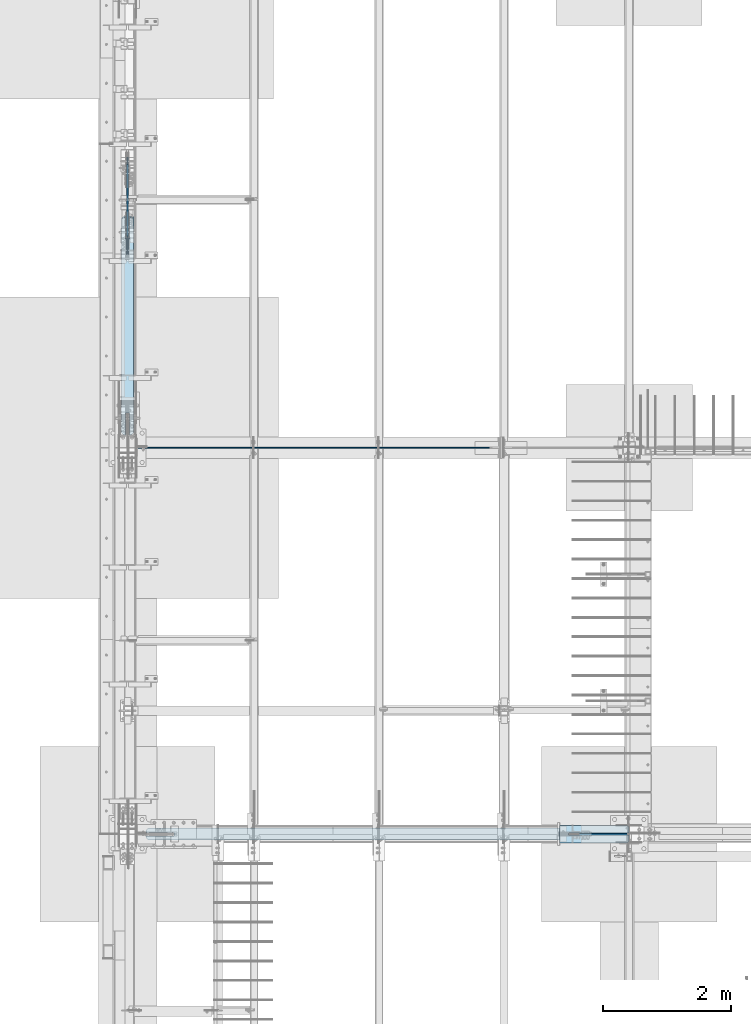
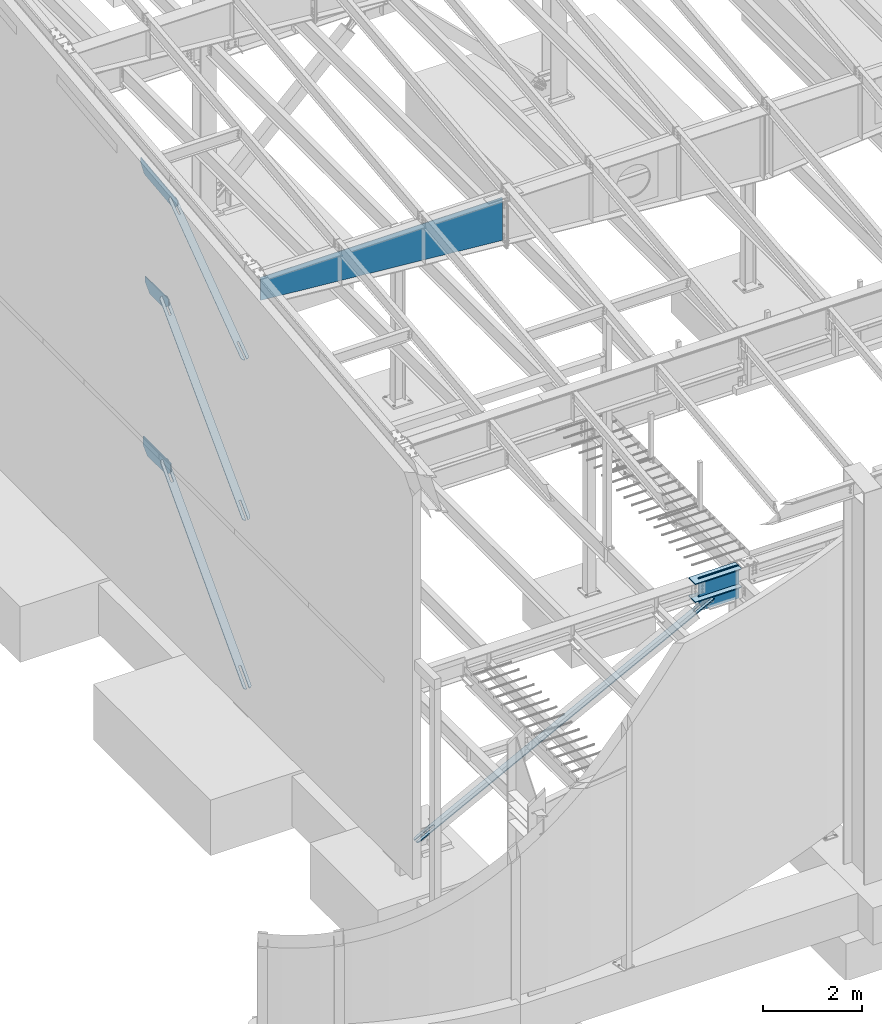
# One storey, part 967 of 1179: 11 plates, 9 elements without a shape of their own.
"""IFC2X3 building model written with IfcOpenShell, lengths in millimetres."""

from ifc_helpers import new_model, si_unit, frame, origin_with_axes, place, context, subcontext, project, spatial, faceted_brep, material, type_object, element, aggregate, save


model = new_model("IFC2X3")

# Units and contexts
model_context = context("Model", 3, precision=1e-05, world=origin_with_axes())
body_context = subcontext(model_context, "Body", "Model", "MODEL_VIEW")
ifc_project = project(units=[si_unit("LENGTHUNIT", "METRE", prefix="MILLI"), si_unit("AREAUNIT", "SQUARE_METRE"), si_unit("VOLUMEUNIT", "CUBIC_METRE"), si_unit("MASSUNIT", "GRAM", prefix="KILO"), si_unit("TIMEUNIT", "SECOND"), si_unit("PLANEANGLEUNIT", "RADIAN"), si_unit("SOLIDANGLEUNIT", "STERADIAN"), si_unit("THERMODYNAMICTEMPERATUREUNIT", "DEGREE_CELSIUS"), si_unit("LUMINOUSINTENSITYUNIT", "LUMEN")], contexts=[model_context])

# Site, building, storey
site_placement = place(None, origin_with_axes())
site = spatial("IfcSite", under=ifc_project, at=site_placement, CompositionType="ELEMENT")
building_placement = place(site_placement, origin_with_axes())
building = spatial("IfcBuilding", under=site, at=building_placement, Name="Undefined", CompositionType="ELEMENT")
storey_placement = place(building_placement, origin_with_axes())
storey = spatial("IfcBuildingStorey", under=building, at=storey_placement, Name="Undefined", CompositionType="ELEMENT", Elevation=0.0)

# Assembly, plate
assembly_1_placement = place(storey_placement, origin_with_axes())
assembly_1 = element("IfcElementAssembly", 1, at=assembly_1_placement, inside=storey, Name="BEAM", AssemblyPlace="NOTDEFINED", PredefinedType="RIGID_FRAME")
ifc_material_1 = material(Name="STEEL/A572-GR.50")
plate_type_1 = type_object("IfcPlateType", PredefinedType="NOTDEFINED")
plate_1_placement = place(assembly_1_placement, frame((431.800000000002, 14878.05, 7539.60905052727), z_axis=(0.0, 1.0, 0.0), x_axis=(0.0, 0.0, 1.0)))
plate_1 = element("IfcPlate", 2, at=plate_1_placement, type_object=plate_type_1, material=ifc_material_1, Name="PLATE", context=body_context, shape_type="Brep", body=[
    faceted_brep([(0.0, -9.52499999999964, 0.0), (-186.309050642565, -9.52500000000146, 190.890420911079), (-186.309050642565, 9.52500000000146, 190.890420911079), (0.0, 9.52499999999964, 0.0), (-186.30905049287, -9.52500000000146, 482.600000483581), (-186.30905049287, 9.52500000000146, 482.600000483581), (-186.309050331894, -9.52500000000146, 761.609579128339), (-186.309050331894, 9.52500000000146, 761.609579128339), (6.76212039252277e-07, -9.52500000000146, 952.499999997119), (6.76212039252277e-07, 9.52500000000146, 952.499999997119), (143.89094955044, -9.52500000000146, 952.500000233997), (143.89094955044, 9.52500000000146, 952.500000233997), (143.890949095251, -9.52500000000146, 0.0), (143.890949095251, 9.52500000000146, 0.0)], [[[0, 1, 2, 3]], [[1, 4, 5, 2]], [[4, 6, 7, 5]], [[6, 8, 9, 7]], [[8, 10, 11, 9]], [[10, 12, 13, 11]], [[12, 0, 3, 13]], [[5, 7, 9, 11, 13, 3, 2]], [[12, 10, 8, 6, 4, 1, 0]]]),
])
aggregate(assembly_1, [plate_1])

# Assembly, plates
assembly_2_placement = place(storey_placement, origin_with_axes())
assembly_2 = element("IfcElementAssembly", 3, at=assembly_2_placement, inside=storey, Name="COLUMN", AssemblyPlace="NOTDEFINED", PredefinedType="RIGID_FRAME")
plate_type_2 = type_object("IfcPlateType", PredefinedType="NOTDEFINED")
plate_2_placement = place(assembly_2_placement, frame((7187.72922453646, 5572.12499999999, 3646.4875), z_axis=(0.0, -1.0, 0.0), x_axis=(1.0, 0.0, 0.0)))
plate_2 = element("IfcPlate", 4, at=plate_2_placement, type_object=plate_type_2, material=ifc_material_1, Name="PLATE", context=body_context, shape_type="Brep", body=[
    faceted_brep([(0.0, -11.1125000000002, 0.0), (0.0, -11.1125000000002, 273.050000000003), (0.0, 11.1125000000002, 273.050000000003), (0.0, 11.1125000000002, 0.0), (1064.88952510486, -11.1125000000002, 273.050006103513), (1064.88952510486, 11.1125000000002, 273.050006103513), (1087.11452548633, -11.1125000000002, 250.825005722043), (1087.11452548633, 11.1125000000002, 250.825005722043), (1087.11452548633, -11.1125000000002, 150.812499999992), (1087.11452548633, 11.1125000000002, 150.812499999992), (154.761317976112, -11.1125000000002, 150.812499999992), (154.761317976112, 11.1125000000002, 150.812499999992), (149.293728290214, -11.1125000000002, 149.724928791709), (149.293728290214, 11.1125000000002, 149.724928791709), (144.65852957017, -11.1125000000002, 146.627788024464), (144.65852957017, 11.1125000000002, 146.627788024464), (141.561388802925, -11.1125000000002, 141.99258930442), (141.561388802925, 11.1125000000002, 141.99258930442), (140.473817594642, -11.1125000000002, 136.525000381463), (140.473817594642, 11.1125000000002, 136.525000381463), (141.561388802925, -11.1125000000002, 131.057410695565), (141.561388802925, 11.1125000000002, 131.057410695565), (144.65852957017, -11.1125000000002, 126.42221197552), (144.65852957017, 11.1125000000002, 126.42221197552), (149.293728290214, -11.1125000000002, 123.325071208275), (149.293728290214, 11.1125000000002, 123.325071208275), (154.761317976112, -11.1125000000002, 122.237499999993), (154.761317976112, 11.1125000000002, 122.237499999993), (1087.11452548633, -11.1125000000002, 122.237499999993), (1087.11452548633, 11.1125000000002, 122.237499999993), (1087.11452548633, -11.1125000000002, 22.2250003814697), (1087.11452548633, 11.1125000000002, 22.2250003814697), (1064.88952510486, -11.1125000000002, 0.0), (1064.88952510486, 11.1125000000002, 0.0)], [[[0, 1, 2, 3]], [[1, 4, 5, 2]], [[4, 6, 7, 5]], [[6, 8, 9, 7]], [[8, 10, 11, 9]], [[10, 12, 13, 11]], [[12, 14, 15, 13]], [[14, 16, 17, 15]], [[16, 18, 19, 17]], [[18, 20, 21, 19]], [[20, 22, 23, 21]], [[22, 24, 25, 23]], [[24, 26, 27, 25]], [[26, 28, 29, 27]], [[28, 30, 31, 29]], [[30, 32, 33, 31]], [[32, 0, 3, 33]], [[5, 7, 9, 11, 13, 15, 17, 19, 21, 23, 25, 27, 29, 31, 33, 3, 2]], [[32, 30, 28, 26, 24, 22, 20, 18, 16, 14, 12, 10, 8, 6, 4, 1, 0]]]),
])
plate_3_placement = place(assembly_2_placement, frame((7187.72922453646, 5572.12499999999, 4090.9875), z_axis=(0.0, -1.0, 0.0), x_axis=(1.0, 0.0, 0.0)))
plate_3 = element("IfcPlate", 5, at=plate_3_placement, type_object=plate_type_2, material=ifc_material_1, Name="PLATE", context=body_context, shape_type="Brep", body=[
    faceted_brep([(0.0, -11.1125000000002, 0.0), (0.0, -11.1125000000002, 273.050000000003), (0.0, 11.1125000000002, 273.050000000003), (0.0, 11.1125000000002, 0.0), (1064.88952510486, -11.1125000000002, 273.050006103513), (1064.88952510486, 11.1125000000002, 273.050006103513), (1087.11452548633, -11.1125000000002, 250.825005722043), (1087.11452548633, 11.1125000000002, 250.825005722043), (1087.11452548633, -11.1125000000002, 150.812499999992), (1087.11452548633, 11.1125000000002, 150.812499999992), (154.761317976112, -11.1125000000002, 150.812499999992), (154.761317976112, 11.1125000000002, 150.812499999992), (149.293728290214, -11.1125000000002, 149.724928791709), (149.293728290214, 11.1125000000002, 149.724928791709), (144.65852957017, -11.1125000000002, 146.627788024464), (144.65852957017, 11.1125000000002, 146.627788024464), (141.561388802925, -11.1125000000002, 141.99258930442), (141.561388802925, 11.1125000000002, 141.99258930442), (140.473817594642, -11.1125000000002, 136.525000381463), (140.473817594642, 11.1125000000002, 136.525000381463), (141.561388802925, -11.1125000000002, 131.057410695565), (141.561388802925, 11.1125000000002, 131.057410695565), (144.65852957017, -11.1125000000002, 126.42221197552), (144.65852957017, 11.1125000000002, 126.42221197552), (149.293728290214, -11.1125000000002, 123.325071208275), (149.293728290214, 11.1125000000002, 123.325071208275), (154.761317976112, -11.1125000000002, 122.237499999993), (154.761317976112, 11.1125000000002, 122.237499999993), (1087.11452548633, -11.1125000000002, 122.237499999993), (1087.11452548633, 11.1125000000002, 122.237499999993), (1087.11452548633, -11.1125000000002, 22.2250003814697), (1087.11452548633, 11.1125000000002, 22.2250003814697), (1064.88952510486, -11.1125000000002, 0.0), (1064.88952510486, 11.1125000000002, 0.0)], [[[0, 1, 2, 3]], [[1, 4, 5, 2]], [[4, 6, 7, 5]], [[6, 8, 9, 7]], [[8, 10, 11, 9]], [[10, 12, 13, 11]], [[12, 14, 15, 13]], [[14, 16, 17, 15]], [[16, 18, 19, 17]], [[18, 20, 21, 19]], [[20, 22, 23, 21]], [[22, 24, 25, 23]], [[24, 26, 27, 25]], [[26, 28, 29, 27]], [[28, 30, 31, 29]], [[30, 32, 33, 31]], [[32, 0, 3, 33]], [[5, 7, 9, 11, 13, 15, 17, 19, 21, 23, 25, 27, 29, 31, 33, 3, 2]], [[32, 30, 28, 26, 24, 22, 20, 18, 16, 14, 12, 10, 8, 6, 4, 1, 0]]]),
])

# Assembly, plate
assembly_3_placement = place(storey_placement, origin_with_axes())
assembly_3 = element("IfcElementAssembly", 6, at=assembly_3_placement, inside=storey, Name="CB", AssemblyPlace="NOTDEFINED", PredefinedType="RIGID_FRAME")
ifc_material_2 = material(Name="STEEL/A36")
plate_type_3 = type_object("IfcPlateType", PredefinedType="NOTDEFINED")
plate_4_placement = place(assembly_3_placement, frame((522.287500000002, 11774.6047955765, 8077.03322111538), z_axis=(0.0, 0.806043266248581, 0.591856615182528), x_axis=(-1.0, 0.0, 0.0)))
plate_4 = element("IfcPlate", 7, at=plate_4_placement, type_object=plate_type_3, material=ifc_material_2, Name="CB", context=body_context, shape_type="Brep", body=[
    faceted_brep([(0.0, -6.34999999991851, 71.4374999999018), (0.0, -6.34999999920291, 3657.25747777707), (0.0, 6.3500000008051, 3657.25747777707), (0.0, 6.35000000007858, 71.4374999999018), (5.43785589622496, -6.34999999919745, 3684.59542547663), (5.43785589622496, 6.35000000080873, 3684.59542547663), (20.923559318986, -6.34999999919199, 3707.77141845805), (20.923559318986, 6.35000000081419, 3707.77141845804), (44.0995523004189, -6.34999999919017, 3723.2571218808), (44.0995523004189, 6.35000000081783, 3723.25712188079), (71.4375, -6.34999999918654, 3728.69497777702), (71.4375, 6.35000000081965, 3728.69497777701), (71.4375, -6.34999999927476, 3321.6724888803), (71.4375, 6.3500000007287, 3321.67248888029), (109.537499999999, -6.34999999927476, 3321.6724888803), (109.537499999999, 6.3500000007287, 3321.67248888029), (109.537499999999, -6.34999999918654, 3728.69497777702), (109.537499999999, 6.35000000081965, 3728.69497777701), (136.87544769958, -6.34999999919017, 3723.2571218808), (136.87544769958, 6.35000000081783, 3723.25712188079), (160.051440681013, -6.34999999919199, 3707.77141845805), (160.051440681013, 6.35000000081419, 3707.77141845804), (175.537144103774, -6.34999999919745, 3684.59542547663), (175.537144103774, 6.35000000080873, 3684.59542547663), (180.974999999999, -6.34999999920291, 3657.25747777707), (180.974999999999, 6.3500000008051, 3657.25747777707), (180.975000000006, -6.34999999991851, 71.4374999999018), (180.975000000006, 6.35000000007858, 71.4374999999018), (175.537144103779, -6.34999999995125, 44.0995523003585), (175.537144103779, 6.35000000004584, 44.0995523003585), (160.051440681018, -6.34999999997672, 20.9235593189551), (160.051440681018, 6.35000000002401, 20.9235593189587), (136.875447699589, -6.34999999999491, 5.43785589621984), (136.875447699589, 6.35000000000218, 5.43785589621621), (109.537500000006, -6.34999999999854, 3.63797880709171e-12), (109.537500000006, 6.35000000000218, 0.0), (109.537499999999, -6.34999999991595, 407.022488896726), (109.537499999999, 6.35000000009114, 407.022488896719), (71.4375, -6.34999999991595, 407.022488896726), (71.4375, 6.35000000009114, 407.022488896719), (71.4375, -6.34999999999854, 3.63797880709171e-12), (71.4375, 6.35000000000218, 0.0), (44.0995523004167, -6.34999999999491, 5.43785589621984), (44.0995523004167, 6.35000000000218, 5.43785589621621), (20.9235593189878, -6.34999999997672, 20.9235593189551), (20.9235593189878, 6.35000000002401, 20.9235593189587), (5.43785589622712, -6.34999999995125, 44.0995523003585), (5.43785589622712, 6.35000000004584, 44.0995523003585)], [[[0, 1, 2, 3]], [[1, 4, 5, 2]], [[4, 6, 7, 5]], [[6, 8, 9, 7]], [[8, 10, 11, 9]], [[10, 12, 13, 11]], [[12, 14, 15, 13]], [[14, 16, 17, 15]], [[16, 18, 19, 17]], [[18, 20, 21, 19]], [[20, 22, 23, 21]], [[22, 24, 25, 23]], [[24, 26, 27, 25]], [[26, 28, 29, 27]], [[28, 30, 31, 29]], [[30, 32, 33, 31]], [[32, 34, 35, 33]], [[34, 36, 37, 35]], [[36, 38, 39, 37]], [[38, 40, 41, 39]], [[40, 42, 43, 41]], [[42, 44, 45, 43]], [[44, 46, 47, 45]], [[46, 0, 3, 47]], [[5, 7, 9, 11, 13, 15, 17, 19, 21, 23, 25, 27, 29, 31, 33, 35, 37, 39, 41, 43, 45, 47, 3, 2]], [[46, 44, 42, 40, 38, 36, 34, 32, 30, 28, 26, 24, 22, 20, 18, 16, 14, 12, 10, 8, 6, 4, 1, 0]]]),
])
aggregate(assembly_3, [plate_4])

assembly_4_placement = place(storey_placement, origin_with_axes())
assembly_4 = element("IfcElementAssembly", 8, at=assembly_4_placement, inside=storey, Name="CB", AssemblyPlace="NOTDEFINED", PredefinedType="RIGID_FRAME")
plate_type_4 = type_object("IfcPlateType", PredefinedType="NOTDEFINED")
plate_5_placement = place(assembly_4_placement, frame((525.462500000002, 11730.1540469199, 4148.03570453558), z_axis=(0.0, 0.698466923036852, 0.715642339037758), x_axis=(-1.0, 0.0, 0.0)))
plate_5 = element("IfcPlate", 9, at=plate_5_placement, type_object=plate_type_4, material=ifc_material_2, Name="CB", context=body_context, shape_type="Brep", body=[
    faceted_brep([(0.0, -9.52500000000691, 71.4375), (0.0, -9.52499999965221, 4791.84892355422), (0.0, 9.52500000033979, 4791.84892355423), (0.0, 9.52500000000327, 71.4374999999909), (5.43785589622496, -9.52499999964857, 4819.1868712538), (5.43785589622496, 9.52500000034343, 4819.18687125381), (20.923559318986, -9.52499999964857, 4842.36286423524), (20.923559318986, 9.52500000034343, 4842.36286423525), (44.0995523004189, -9.52499999964493, 4857.848567658), (44.0995523004189, 9.52500000034343, 4857.84856765801), (71.4375, -9.52499999964493, 4863.28642355423), (71.4375, 9.52500000034706, 4863.28642355424), (71.4375, -9.52499999967404, 4441.70468275449), (71.4375, 9.52500000031432, 4441.7046827545), (115.8875, -9.52499999967404, 4441.70468275449), (115.8875, 9.52500000031432, 4441.7046827545), (115.8875, -9.52499999964493, 4863.28642355423), (115.8875, 9.52500000034706, 4863.28642355424), (143.225447699581, -9.52499999964493, 4857.848567658), (143.225447699581, 9.52500000034343, 4857.84856765801), (166.401440681014, -9.52499999964857, 4842.36286423524), (166.401440681014, 9.52500000034343, 4842.36286423525), (181.887144103775, -9.52499999964857, 4819.1868712538), (181.887144103775, 9.52500000034343, 4819.18687125381), (187.325, -9.52499999965221, 4791.84892355422), (187.325, 9.52500000033979, 4791.84892355423), (187.324999999997, -9.52500000000691, 71.4375), (187.324999999997, 9.52500000000327, 71.4374999999909), (181.88714410377, -9.52500000000691, 44.0995523004203), (181.88714410377, 9.52500000000509, 44.0995523004112), (166.401440681009, -9.52500000000691, 20.9235593189915), (166.401440681009, 9.52500000000509, 20.9235593189787), (143.22544769958, -9.52500000000327, 5.43785589623076), (143.22544769958, 9.52500000000509, 5.43785589621621), (115.887499999997, -9.52500000000509, 5.45696821063757e-12), (115.887499999997, 9.52500000000691, -7.27595761418343e-12), (115.887499999997, -9.52500000001783, 421.581740798863), (115.887499999997, 9.52499999999418, 421.581740798851), (71.4375, -9.52500000001783, 421.581740798863), (71.4375, 9.52499999999418, 421.581740798851), (71.4375, -9.52500000000509, 5.45696821063757e-12), (71.4375, 9.52500000000691, -7.27595761418343e-12), (44.0995523004167, -9.52500000000327, 5.43785589623076), (44.0995523004167, 9.52500000000509, 5.43785589621621), (20.9235593189878, -9.52500000000691, 20.9235593189915), (20.9235593189878, 9.52500000000509, 20.9235593189787), (5.43785589622712, -9.52500000000691, 44.0995523004203), (5.43785589622712, 9.52500000000509, 44.0995523004112)], [[[0, 1, 2, 3]], [[1, 4, 5, 2]], [[4, 6, 7, 5]], [[6, 8, 9, 7]], [[8, 10, 11, 9]], [[10, 12, 13, 11]], [[12, 14, 15, 13]], [[14, 16, 17, 15]], [[16, 18, 19, 17]], [[18, 20, 21, 19]], [[20, 22, 23, 21]], [[22, 24, 25, 23]], [[24, 26, 27, 25]], [[26, 28, 29, 27]], [[28, 30, 31, 29]], [[30, 32, 33, 31]], [[32, 34, 35, 33]], [[34, 36, 37, 35]], [[36, 38, 39, 37]], [[38, 40, 41, 39]], [[40, 42, 43, 41]], [[42, 44, 45, 43]], [[44, 46, 47, 45]], [[46, 0, 3, 47]], [[5, 7, 9, 11, 13, 15, 17, 19, 21, 23, 25, 27, 29, 31, 33, 35, 37, 39, 41, 43, 45, 47, 3, 2]], [[46, 44, 42, 40, 38, 36, 34, 32, 30, 28, 26, 24, 22, 20, 18, 16, 14, 12, 10, 8, 6, 4, 1, 0]]]),
])
aggregate(assembly_4, [plate_5])

assembly_5_placement = place(storey_placement, origin_with_axes())
assembly_5 = element("IfcElementAssembly", 10, at=assembly_5_placement, inside=storey, Name="BEAM", AssemblyPlace="NOTDEFINED", PredefinedType="RIGID_FRAME")
plate_type_5 = type_object("IfcPlateType", PredefinedType="NOTDEFINED")
plate_6_placement = place(assembly_5_placement, frame((431.800000000002, 14793.6602577624, 3473.77993843472), z_axis=(0.0, 1.0, 0.0), x_axis=(0.0, 0.0, 1.0)))
plate_6 = element("IfcPlate", 11, at=plate_6_placement, type_object=plate_type_5, material=ifc_material_1, Name="PLATE", context=body_context, shape_type="Brep", body=[
    faceted_brep([(0.0, -12.7, 0.0), (-165.530801027491, -12.7, 175.571193903201), (-165.530801027491, 12.7, 175.571193903201), (0.0, 12.7, 0.0), (-165.530801027491, -12.7, 566.989741928064), (-165.530801027491, 12.7, 566.989741928064), (-165.530801027491, -12.7, 945.708290572049), (-165.530801027491, 12.7, 945.708290572049), (-3.09023562294897e-07, -12.7, 1121.27948414748), (-3.09023562294897e-07, 12.7, 1121.27948414748), (209.22006156528, -12.7, 1121.27948414748), (209.22006156528, 12.7, 1121.27948414748), (209.22006156528, -12.7, -3.63797880709171e-12), (209.22006156528, 12.7, -3.63797880709171e-12)], [[[0, 1, 2, 3]], [[1, 4, 5, 2]], [[4, 6, 7, 5]], [[6, 8, 9, 7]], [[8, 10, 11, 9]], [[10, 12, 13, 11]], [[12, 0, 3, 13]], [[5, 7, 9, 11, 13, 3, 2]], [[12, 10, 8, 6, 4, 1, 0]]]),
])
aggregate(assembly_5, [plate_6])

assembly_6_placement = place(storey_placement, origin_with_axes())
assembly_6 = element("IfcElementAssembly", 12, at=assembly_6_placement, inside=storey, Name="BEAM", AssemblyPlace="NOTDEFINED", PredefinedType="RIGID_FRAME")
plate_type_6 = type_object("IfcPlateType", PredefinedType="NOTDEFINED")
plate_7_placement = place(assembly_6_placement, frame((431.800000000002, 14510.7830601413, 10333.8087306105), z_axis=(0.0, 0.993676146336441, 0.112284087038017), x_axis=(0.0, 0.112284087038014, -0.993676146336441)))
plate_7 = element("IfcPlate", 13, at=plate_7_placement, type_object=plate_type_6, material=ifc_material_1, Name="PLATE", context=body_context, shape_type="Brep", body=[
    faceted_brep([(0.0, -9.52499999999964, 0.0), (1.81898940354586e-12, -9.52499999999998, 1514.91883981534), (1.81898940354586e-12, 9.52499999999998, 1514.91883981534), (0.0, 9.52499999999964, 0.0), (107.459666727778, -9.52499999999998, 1514.91690998717), (107.459666727778, 9.52499999999998, 1514.91690998717), (302.953810228, -9.52499999999998, 1334.29336942057), (302.953810228, 9.52499999999998, 1334.29336942057), (302.953810227998, -9.52499999999998, 886.268838703136), (302.953810227998, 9.52499999999998, 886.268838703136), (302.953810227995, -9.52499999999998, 118.410072533348), (302.953810227995, 9.52499999999998, 118.410072533348), (96.5480736647896, -9.52499999999998, -5.45696821063757e-12), (96.5480736647896, 9.52499999999998, -5.45696821063757e-12)], [[[0, 1, 2, 3]], [[1, 4, 5, 2]], [[4, 6, 7, 5]], [[6, 8, 9, 7]], [[8, 10, 11, 9]], [[10, 12, 13, 11]], [[12, 0, 3, 13]], [[5, 7, 9, 11, 13, 3, 2]], [[12, 10, 8, 6, 4, 1, 0]]]),
])
aggregate(assembly_6, [plate_7])

assembly_7_placement = place(storey_placement, origin_with_axes())
assembly_7 = element("IfcElementAssembly", 14, at=assembly_7_placement, inside=storey, Name="CB", AssemblyPlace="NOTDEFINED", PredefinedType="RIGID_FRAME")
plate_type_7 = type_object("IfcPlateType", PredefinedType="NOTDEFINED")
plate_8_placement = place(assembly_7_placement, frame((527.050000000002, 11690.4530167881, 6.46967521355509), z_axis=(0.0, 0.685995858758672, 0.727605443744034), x_axis=(-1.0, 0.0, 0.0)))
plate_8 = element("IfcPlate", 15, at=plate_8_placement, type_object=plate_type_7, material=ifc_material_2, Name="CB", context=body_context, shape_type="Brep", body=[
    faceted_brep([(0.0, -12.700000000139, 66.6750030518815), (0.0, -12.7000000021235, 4899.51727466588), (0.0, 12.6999999978489, 4899.5172746659), (0.0, 12.6999999998006, 66.6750030519361), (5.0753324021112, -12.7000000021344, 4925.03269368669), (5.0753324021112, 12.6999999978379, 4925.03269368671), (19.5286562582261, -12.7000000021453, 4946.66362145943), (19.5286562582261, 12.699999997827, 4946.66362145945), (41.1595840309583, -12.7000000021508, 4961.11694531555), (41.1595840309583, 12.6999999978198, 4961.11694531558), (66.675, -12.7000000021526, 4966.19227771766), (66.675, 12.6999999978179, 4966.19227771769), (66.675, -12.7000000019343, 4467.47113886627), (66.675, 12.6999999980362, 4467.4711388663), (123.825, -12.7000000019343, 4467.47113886627), (123.825, 12.6999999980362, 4467.4711388663), (123.824996948242, -12.7000000021526, 4966.19227771766), (123.824996948242, 12.6999999978179, 4966.19227771769), (149.340415969042, -12.7000000021508, 4961.11694531555), (149.340415969042, 12.6999999978198, 4961.11694531558), (170.971343741774, -12.7000000021453, 4946.66362145943), (170.971343741774, 12.699999997827, 4946.66362145945), (185.424667597889, -12.7000000021344, 4925.03269368669), (185.424667597889, 12.6999999978379, 4925.03269368671), (190.5, -12.7000000021235, 4899.51727466588), (190.5, 12.6999999978489, 4899.5172746659), (190.5, -12.700000000139, 66.6750030518815), (190.5, 12.6999999998006, 66.6750030519361), (185.424667597889, -12.7000000000735, 41.159584031022), (185.424667597889, 12.6999999998661, 41.1595840310729), (170.971343741774, -12.7000000000189, 19.5286562582405), (170.971343741774, 12.6999999999171, 19.5286562582951), (149.340415969042, -12.6999999999825, 5.07533240209159), (149.340415969042, 12.6999999999571, 5.07533240214616), (123.824999618709, -12.7000000000002, 0.0), (123.8249996187, 12.6999999999996, 0.0), (123.825, -12.7000000002045, 498.721138851377), (123.825, 12.6999999997697, 498.721138851402), (66.675, -12.7000000002045, 498.721138851377), (66.675, 12.6999999997697, 498.721138851402), (66.6750030517578, -12.699999999968, -2.91038304567337e-11), (66.6750030517578, 12.699999999968, 2.91038304567337e-11), (41.1595840309583, -12.6999999999825, 5.07533240209159), (41.1595840309583, 12.6999999999571, 5.07533240214616), (19.5286562582261, -12.7000000000189, 19.5286562582405), (19.5286562582261, 12.6999999999171, 19.5286562582951), (5.0753324021112, -12.7000000000735, 41.159584031022), (5.0753324021112, 12.6999999998661, 41.1595840310729)], [[[0, 1, 2, 3]], [[1, 4, 5, 2]], [[4, 6, 7, 5]], [[6, 8, 9, 7]], [[8, 10, 11, 9]], [[10, 12, 13, 11]], [[12, 14, 15, 13]], [[14, 16, 17, 15]], [[16, 18, 19, 17]], [[18, 20, 21, 19]], [[20, 22, 23, 21]], [[22, 24, 25, 23]], [[24, 26, 27, 25]], [[26, 28, 29, 27]], [[28, 30, 31, 29]], [[30, 32, 33, 31]], [[32, 34, 35, 33]], [[34, 36, 37, 35]], [[36, 38, 39, 37]], [[38, 40, 41, 39]], [[40, 42, 43, 41]], [[42, 44, 45, 43]], [[44, 46, 47, 45]], [[46, 0, 3, 47]], [[5, 7, 9, 11, 13, 15, 17, 19, 21, 23, 25, 27, 29, 31, 33, 35, 37, 39, 41, 43, 45, 47, 3, 2]], [[46, 44, 42, 40, 38, 36, 34, 32, 30, 28, 26, 24, 22, 20, 18, 16, 14, 12, 10, 8, 6, 4, 1, 0]]]),
])
aggregate(assembly_7, [plate_8])

assembly_8_placement = place(storey_placement, origin_with_axes())
assembly_8 = element("IfcElementAssembly", 16, at=assembly_8_placement, inside=storey, Name="CB", AssemblyPlace="NOTDEFINED", PredefinedType="RIGID_FRAME")
plate_9_placement = place(assembly_8_placement, frame((724.286778625474, 5340.35, -63.6814843327415), z_axis=(0.88706105467266, 0.0, 0.461652125829643), x_axis=(0.0, 1.0, 0.0)))
plate_9 = element("IfcPlate", 17, at=plate_9_placement, type_object=plate_type_7, material=ifc_material_2, Name="CB", context=body_context, shape_type="Brep", body=[
    faceted_brep([(0.0, -12.700000000139, 66.6750030518815), (0.0, -12.7000000001311, 7769.71727464519), (0.0, 12.699999999869, 7769.71727464519), (0.0, 12.6999999998006, 66.6750030519361), (5.0753324021116, -12.7000000001315, 7795.23269366599), (5.0753324021116, 12.699999999869, 7795.23269366599), (19.528656258226, -12.7000000001315, 7816.86362143873), (19.528656258226, 12.699999999869, 7816.86362143873), (41.1595840309583, -12.700000000132, 7831.31694529484), (41.1595840309583, 12.6999999998686, 7831.31694529484), (66.6750000000002, -12.700000000132, 7836.39227769695), (66.6750000000002, 12.6999999998686, 7836.39227769695), (66.6750000000002, -12.7000000001238, 7337.67113884757), (66.6750000000002, 12.6999999998772, 7337.67113884756), (123.825, -12.7000000001238, 7337.67113884757), (123.825, 12.6999999998772, 7337.67113884756), (123.824996948242, -12.700000000132, 7836.39227769695), (123.824996948242, 12.6999999998686, 7836.39227769695), (149.340415969042, -12.700000000132, 7831.31694529484), (149.340415969042, 12.6999999998686, 7831.31694529484), (170.971343741774, -12.7000000001315, 7816.86362143873), (170.971343741774, 12.699999999869, 7816.86362143873), (185.424667597888, -12.7000000001315, 7795.23269366599), (185.424667597888, 12.699999999869, 7795.23269366599), (190.5, -12.7000000001311, 7769.71727464519), (190.5, 12.699999999869, 7769.71727464519), (190.5, -12.700000000139, 66.6750030518815), (190.5, 12.6999999998006, 66.6750030519361), (185.424667597889, -12.7000000000735, 41.159584031022), (185.424667597889, 12.6999999998661, 41.1595840310729), (170.971343741774, -12.7000000000189, 19.5286562582405), (170.971343741774, 12.6999999999171, 19.5286562582951), (149.340415969042, -12.6999999999825, 5.07533240209159), (149.340415969042, 12.6999999999571, 5.07533240214616), (123.824999618709, -12.7000000000002, 0.0), (123.8249996187, 12.6999999999996, 0.0), (123.825, -12.7000000002045, 498.721138851377), (123.825, 12.6999999997697, 498.721138851402), (66.675, -12.7000000002045, 498.721138851377), (66.675, 12.6999999997697, 498.721138851402), (66.6750030517578, -12.699999999968, -2.91038304567337e-11), (66.6750030517578, 12.699999999968, 2.91038304567337e-11), (41.1595840309583, -12.6999999999825, 5.07533240209159), (41.1595840309583, 12.6999999999571, 5.07533240214616), (19.5286562582261, -12.7000000000189, 19.5286562582405), (19.5286562582261, 12.6999999999171, 19.5286562582951), (5.0753324021112, -12.7000000000735, 41.159584031022), (5.0753324021112, 12.6999999998661, 41.1595840310729)], [[[0, 1, 2, 3]], [[1, 4, 5, 2]], [[4, 6, 7, 5]], [[6, 8, 9, 7]], [[8, 10, 11, 9]], [[10, 12, 13, 11]], [[12, 14, 15, 13]], [[14, 16, 17, 15]], [[16, 18, 19, 17]], [[18, 20, 21, 19]], [[20, 22, 23, 21]], [[22, 24, 25, 23]], [[24, 26, 27, 25]], [[26, 28, 29, 27]], [[28, 30, 31, 29]], [[30, 32, 33, 31]], [[32, 34, 35, 33]], [[34, 36, 37, 35]], [[36, 38, 39, 37]], [[38, 40, 41, 39]], [[40, 42, 43, 41]], [[42, 44, 45, 43]], [[44, 46, 47, 45]], [[46, 0, 3, 47]], [[5, 7, 9, 11, 13, 15, 17, 19, 21, 23, 25, 27, 29, 31, 33, 35, 37, 39, 41, 43, 45, 47, 3, 2]], [[46, 44, 42, 40, 38, 36, 34, 32, 30, 28, 26, 24, 22, 20, 18, 16, 14, 12, 10, 8, 6, 4, 1, 0]]]),
])
aggregate(assembly_8, [plate_9])

# Plate
plate_type_8 = type_object("IfcPlateType", PredefinedType="NOTDEFINED")
plate_10_placement = place(assembly_2_placement, frame((7340.9030421311, 5435.6, 4121.15000140013), z_axis=(0.0, 0.0, -1.0), x_axis=(1.0, 0.0, 0.0)))
plate_10 = element("IfcPlate", 18, at=plate_10_placement, type_object=plate_type_8, material=ifc_material_1, Name="PLATE", context=body_context, shape_type="Brep", body=[
    faceted_brep([(0.0, -12.7, 0.0), (0.0, -12.6999999999998, 605.342850626418), (0.0, 12.6999999999998, 605.342850626418), (0.0, 12.7, 0.0), (111.396657962692, -12.6999999999998, 819.390683118931), (111.396657962692, 12.6999999999998, 819.390683118931), (933.940707891687, -12.6999999999998, 819.390683117192), (933.940707891687, 12.6999999999998, 819.390683117192), (933.940707891687, -12.6999999999998, 0.0), (933.940707891687, 12.6999999999998, 0.0)], [[[0, 1, 2, 3]], [[1, 4, 5, 2]], [[4, 6, 7, 5]], [[6, 8, 9, 7]], [[8, 0, 3, 9]], [[5, 7, 9, 3, 2]], [[8, 6, 4, 1, 0]]]),
])

aggregate(assembly_2, [plate_2, plate_3, plate_10])

# Assembly, plate
assembly_9_placement = place(storey_placement, origin_with_axes())
assembly_9 = element("IfcElementAssembly", 19, at=assembly_9_placement, inside=storey, Name="RAFTER BEAM", AssemblyPlace="NOTDEFINED", PredefinedType="RIGID_FRAME")
plate_type_9 = type_object("IfcPlateType", PredefinedType="NOTDEFINED")
plate_11_placement = place(assembly_9_placement, frame((6273.8, 11480.8093353614, 10229.87135672), z_axis=(0.0, 0.0, -1.0), x_axis=(-1.0, 0.0, 0.0)))
plate_11 = element("IfcPlate", 20, at=plate_11_placement, type_object=plate_type_9, material=ifc_material_2, Name="RAFTER BEAM", context=body_context, shape_type="Brep", body=[
    faceted_brep([(5672.13750000165, -7.9375, 565.069754352626), (5672.1375, -7.9375, 0.0), (5672.1375, 7.9375, 0.0), (5672.13750000165, 7.9375, 565.069754352626), (25.4000000002561, -7.9375, 1059.81203938672), (25.4000000002561, -7.9375, 0.0), (25.4000000002561, 7.9375, 0.0), (25.4000000002561, 7.9375, 1059.81203938672)], [[[0, 1, 2, 3]], [[1, 0, 4, 5]], [[2, 1, 5, 6]], [[3, 2, 6, 7]], [[0, 3, 7, 4]], [[6, 5, 4, 7]]]),
])
aggregate(assembly_9, [plate_11])

save(model, "model.ifc")
